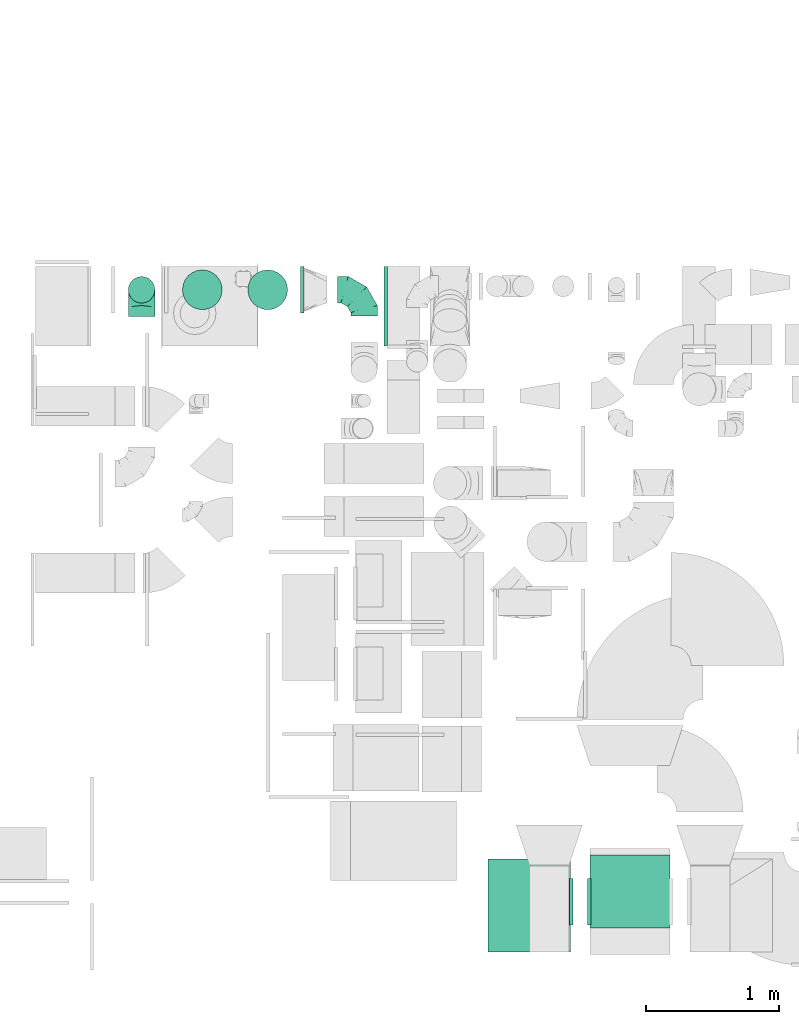
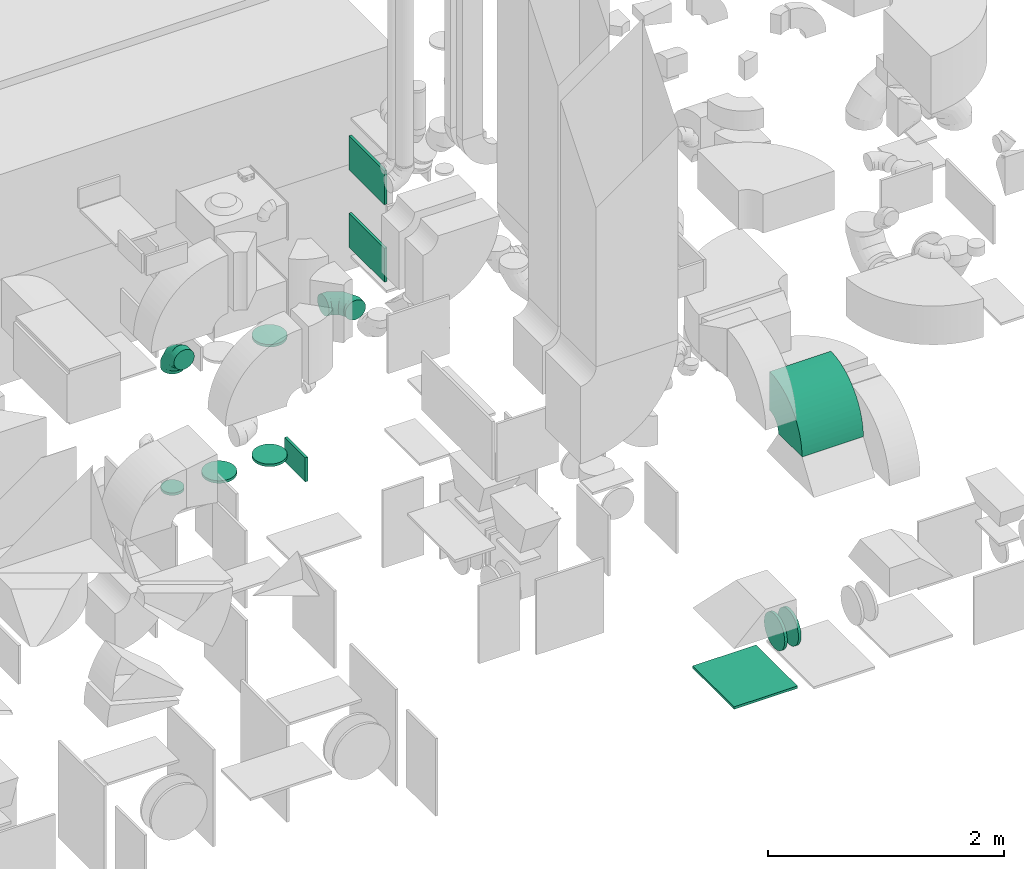
# One storey, part 19 of 59: 13 flow fittings.
"""IFC2X3 building model written with IfcOpenShell, lengths in millimetres."""

from ifc_helpers import new_model, entity, si_unit, converted_unit, derived_unit, direction, frame, frame_2d, origin, origin_2d_with_axis, place, context, subcontext, project, spatial, polyline, circle_curve, parameter, trimmed, segment, composite_curve, rectangle, outline, extrude, faceted_brep, source, transform, mapped, material, type_object, type_shapes, element, save


model = new_model("IFC2X3")

# Units and contexts
model_context = context("Model", 3, precision=0.01, world=origin(), true_north=direction((6.12303176911189e-17, 1.0)))
body_context = subcontext(model_context, "Body", "Model", "MODEL_VIEW")
ifc_project = project(units=[si_unit("LENGTHUNIT", "METRE", prefix="MILLI"), si_unit("AREAUNIT", "SQUARE_METRE"), si_unit("VOLUMEUNIT", "CUBIC_METRE"), converted_unit("PLANEANGLEUNIT", "DEGREE", entity("IfcRatioMeasure", 0.0174532925199433), si_unit("PLANEANGLEUNIT", "RADIAN"), dimensions=[0, 0, 0, 0, 0, 0, 0]), si_unit("MASSUNIT", "GRAM", prefix="KILO"), derived_unit("MASSDENSITYUNIT", [(si_unit("MASSUNIT", "GRAM", prefix="KILO"), 1), (si_unit("LENGTHUNIT", "METRE"), -3)]), derived_unit("MOMENTOFINERTIAUNIT", [(si_unit("LENGTHUNIT", "METRE"), 4)]), si_unit("TIMEUNIT", "SECOND"), si_unit("FREQUENCYUNIT", "HERTZ"), si_unit("THERMODYNAMICTEMPERATUREUNIT", "DEGREE_CELSIUS"), derived_unit("THERMALTRANSMITTANCEUNIT", [(si_unit("MASSUNIT", "GRAM", prefix="KILO"), 1), (si_unit("THERMODYNAMICTEMPERATUREUNIT", "KELVIN"), -1), (si_unit("TIMEUNIT", "SECOND"), -3)]), derived_unit("VOLUMETRICFLOWRATEUNIT", [(si_unit("LENGTHUNIT", "METRE"), 3), (si_unit("TIMEUNIT", "SECOND"), -1)]), derived_unit("MASSFLOWRATEUNIT", [(si_unit("MASSUNIT", "GRAM", prefix="KILO"), 1), (si_unit("TIMEUNIT", "SECOND"), -1)]), derived_unit("ROTATIONALFREQUENCYUNIT", [(si_unit("TIMEUNIT", "SECOND"), -1)]), si_unit("ELECTRICCURRENTUNIT", "AMPERE"), si_unit("ELECTRICVOLTAGEUNIT", "VOLT"), si_unit("POWERUNIT", "WATT"), si_unit("FORCEUNIT", "NEWTON", prefix="KILO"), si_unit("ILLUMINANCEUNIT", "LUX"), si_unit("LUMINOUSFLUXUNIT", "LUMEN"), si_unit("LUMINOUSINTENSITYUNIT", "CANDELA"), derived_unit("USERDEFINED", [(si_unit("MASSUNIT", "GRAM", prefix="KILO"), -1), (si_unit("LENGTHUNIT", "METRE"), -2), (si_unit("TIMEUNIT", "SECOND"), 3), (si_unit("LUMINOUSFLUXUNIT", "LUMEN"), 1)]), derived_unit("LINEARVELOCITYUNIT", [(si_unit("LENGTHUNIT", "METRE"), 1), (si_unit("TIMEUNIT", "SECOND"), -1)]), si_unit("PRESSUREUNIT", "PASCAL"), derived_unit("USERDEFINED", [(si_unit("LENGTHUNIT", "METRE"), -2), (si_unit("MASSUNIT", "GRAM", prefix="KILO"), 1), (si_unit("TIMEUNIT", "SECOND"), -2)]), derived_unit("LINEARFORCEUNIT", [(si_unit("MASSUNIT", "GRAM", prefix="KILO"), 1), (si_unit("LENGTHUNIT", "METRE"), 1), (si_unit("TIMEUNIT", "SECOND"), -2), (si_unit("LENGTHUNIT", "METRE"), -1)]), derived_unit("PLANARFORCEUNIT", [(si_unit("MASSUNIT", "GRAM", prefix="KILO"), 1), (si_unit("LENGTHUNIT", "METRE"), 1), (si_unit("TIMEUNIT", "SECOND"), -2), (si_unit("LENGTHUNIT", "METRE"), -2)])], contexts=[model_context])

# Site, building, storey
site_placement = place(None, origin())
site = spatial("IfcSite", under=ifc_project, at=site_placement, CompositionType="ELEMENT")
building_placement = place(site_placement, origin())
building = spatial("IfcBuilding", under=site, at=building_placement, CompositionType="ELEMENT")
storey_placement = place(building_placement, frame((0.0, 0.0, 28200.0)))
storey = spatial("IfcBuildingStorey", under=building, at=storey_placement, CompositionType="ELEMENT", Elevation=28200.0)

# Flow fittings
ifc_material = material()
duct_fitting_type_1 = type_object("IfcDuctFittingType", PredefinedType="NOTDEFINED", material=ifc_material)
shared_shape_1 = source(origin(), body_context, "Body", "SweptSolid", [
    extrude(rectangle(XDim=24.9999999999999, YDim=350.0, at=origin_2d_with_axis()), frame((12.5, 0.0, -125.0)), (0.0, 0.0, 1.0), 250.0),
])
type_shapes(duct_fitting_type_1, [shared_shape_1])
flow_fitting_1_placement = place(storey_placement, frame((47891.97, 12998.12, 325.0)))
element("IfcFlowFitting", 1, at=flow_fitting_1_placement, inside=storey, type_object=duct_fitting_type_1, material=ifc_material, context=body_context, shape_type="MappedRepresentation", body=[
    mapped(shared_shape_1, transform((0.0, 0.0, 0.0), scale=1.0)),
])
duct_fitting_type_2 = type_object("IfcDuctFittingType", PredefinedType="NOTDEFINED", material=ifc_material)
shared_shape_2 = source(origin(), body_context, "Body", "SweptSolid", [
    extrude(rectangle(XDim=350.0, YDim=26.096, at=origin_2d_with_axis()), frame((6.95, 0.0, -300.0), z_axis=(0.0, 0.0, 1.0), x_axis=(0.0, -1.0, 0.0)), (0.0, 0.0, 1.0), 600.0),
])
type_shapes(duct_fitting_type_2, [shared_shape_2])
for number, where, z_axis, x_axis in (
    (2, (48542.04, 12874.75, 2370.0), (0.0, 1.0, 0.0), (-1.0, 0.0, 0.0)),
    (3, (48542.04, 12874.75, 3170.0), (0.0, 1.0, 0.0), (-1.0, 0.0, 0.0)),
):
    element("IfcFlowFitting", number, at=place(storey_placement, frame(where, z_axis=z_axis, x_axis=x_axis)), inside=storey, type_object=duct_fitting_type_2, material=ifc_material, context=body_context, shape_type="MappedRepresentation", body=[
        mapped(shared_shape_2, transform((0.0, 0.0, 0.0), scale=1.0)),
    ])
duct_fitting_type_3 = type_object("IfcDuctFittingType", PredefinedType="NOTDEFINED", material=ifc_material)
shared_shape_3 = source(origin(), body_context, "Body", "SweptSolid", [
    extrude(rectangle(XDim=24.9999999999999, YDim=620.0, at=origin_2d_with_axis()), frame((12.5, 0.0, -350.0)), (0.0, 0.0, 1.0), 700.0),
])
type_shapes(duct_fitting_type_3, [shared_shape_3])
flow_fitting_2_placement = place(storey_placement, frame((49615.11, 8360.0, 300.0), z_axis=(0.0, 1.0, 0.0), x_axis=(0.0, 0.0, -1.0)))
element("IfcFlowFitting", 4, at=flow_fitting_2_placement, inside=storey, type_object=duct_fitting_type_3, material=ifc_material, context=body_context, shape_type="MappedRepresentation", body=[
    mapped(shared_shape_3, transform((0.0, 0.0, 0.0), scale=1.0)),
])
duct_fitting_type_4 = type_object("IfcDuctFittingType", PredefinedType="NOTDEFINED", material=ifc_material)
shared_shape_4 = source(origin(), body_context, "Body", "Brep", [
    faceted_brep([(-200.0, 0.0, -100.0), (-200.0, -25.88, -96.59), (-200.0, -50.0, -86.6), (-200.0, -70.71, -70.71), (-200.0, -86.6, -50.0), (-200.0, -96.59, -25.88), (-200.0, -100.0, 0.0), (-200.0, -96.59, 25.88), (-200.0, -86.6, 50.0), (-200.0, -70.71, 70.71), (-200.0, -50.0, 86.6), (-200.0, -25.88, 96.59), (-200.0, 0.0, 100.0), (-200.0, 25.88, 96.59), (-200.0, 50.0, 86.6), (-200.0, 70.71, 70.71), (-200.0, 86.6, 50.0), (-200.0, 96.59, 25.88), (-200.0, 100.0, 0.0), (-200.0, 96.59, -25.88), (-200.0, 86.6, -50.0), (-200.0, 70.71, -70.71), (-200.0, 50.0, -86.6), (-200.0, 25.88, -96.59), (-153.35, 25.88, 96.59), (-159.81, 50.0, 86.6), (-146.41, 0.0, 100.0), (-165.36, 70.71, 70.71), (-172.29, 96.59, 25.88), (-173.21, 100.0, 0.0), (-169.62, 86.6, 50.0), (-169.62, 86.6, -50.0), (-165.36, 70.71, -70.71), (-172.29, 96.59, -25.88), (-153.35, 25.88, -96.59), (-146.41, 0.0, -100.0), (-159.81, 50.0, -86.6), (-139.48, -25.88, -96.59), (-133.01, -50.0, -86.6), (-127.46, -70.71, -70.71), (-123.21, -86.6, -50.0), (-120.53, -96.59, -25.88), (-119.62, -100.0, 0.0), (-120.53, -96.59, 25.88), (-123.21, -86.6, 50.0), (-127.46, -70.71, 70.71), (-133.01, -50.0, 86.6), (-139.48, -25.88, 96.59), (-72.54, 72.54, 96.59), (-90.19, 90.19, 86.6), (-53.59, 53.59, 100.0), (-105.35, 105.35, 70.71), (-116.99, 116.99, 50.0), (-124.3, 124.3, 25.88), (-126.79, 126.79, 0.0), (-124.3, 124.3, -25.88), (-116.99, 116.99, -50.0), (-105.35, 105.35, -70.71), (-72.54, 72.54, -96.59), (-53.59, 53.59, -100.0), (-90.19, 90.19, -86.6), (-34.64, 34.64, -96.59), (-16.99, 16.99, -86.6), (-1.83, 1.83, -70.71), (9.81, -9.81, -50.0), (17.12, -17.12, -25.88), (19.62, -19.62, 0.0), (17.12, -17.12, 25.88), (9.81, -9.81, 50.0), (-1.83, 1.83, 70.71), (-16.99, 16.99, 86.6), (-34.64, 34.64, 96.59), (-25.88, 153.35, 96.59), (-50.0, 159.81, 86.6), (0.0, 146.41, 100.0), (-70.71, 165.36, 70.71), (-86.6, 169.62, 50.0), (-96.59, 172.29, 25.88), (-100.0, 173.21, 0.0), (-96.59, 172.29, -25.88), (-86.6, 169.62, -50.0), (-70.71, 165.36, -70.71), (-25.88, 153.35, -96.59), (0.0, 146.41, -100.0), (-50.0, 159.81, -86.6), (25.88, 139.48, -96.59), (50.0, 133.01, -86.6), (70.71, 127.46, -70.71), (86.6, 123.21, -50.0), (96.59, 120.53, -25.88), (100.0, 119.62, 0.0), (96.59, 120.53, 25.88), (86.6, 123.21, 50.0), (70.71, 127.46, 70.71), (50.0, 133.01, 86.6), (25.88, 139.48, 96.59), (-25.88, 200.0, -96.59), (-50.0, 200.0, -86.6), (-70.71, 200.0, -70.71), (-86.6, 200.0, -50.0), (-96.59, 200.0, -25.88), (-100.0, 200.0, 0.0), (-96.59, 200.0, 25.88), (-86.6, 200.0, 50.0), (-70.71, 200.0, 70.71), (-50.0, 200.0, 86.6), (-25.88, 200.0, 96.59), (0.0, 200.0, 100.0), (25.88, 200.0, 96.59), (50.0, 200.0, 86.6), (70.71, 200.0, 70.71), (86.6, 200.0, 50.0), (96.59, 200.0, 25.88), (100.0, 200.0, 0.0), (96.59, 200.0, -25.88), (86.6, 200.0, -50.0), (70.71, 200.0, -70.71), (50.0, 200.0, -86.6), (25.88, 200.0, -96.59), (0.0, 200.0, -100.0)], [[[0, 1, 2, 3, 4, 5, 6, 7, 8, 9, 10, 11, 12, 13, 14, 15, 16, 17, 18, 19, 20, 21, 22, 23]], [[24, 25, 14, 13]], [[26, 24, 13, 12]], [[14, 25, 27, 15]], [[28, 29, 18, 17]], [[30, 28, 17, 16]], [[15, 27, 30, 16]], [[20, 31, 32, 21]], [[33, 31, 20, 19]], [[18, 29, 33, 19]], [[34, 35, 0, 23]], [[36, 34, 23, 22]], [[32, 36, 22, 21]], [[1, 0, 35, 37]], [[2, 1, 37, 38]], [[38, 39, 3, 2]], [[5, 4, 40, 41]], [[6, 5, 41, 42]], [[39, 40, 4, 3]], [[6, 42, 43, 7]], [[7, 43, 44, 8]], [[8, 44, 45, 9]], [[9, 45, 46, 10]], [[10, 46, 47, 11]], [[26, 12, 11, 47]], [[48, 49, 25, 24]], [[50, 48, 24, 26]], [[27, 25, 49, 51]], [[52, 53, 28, 30]], [[51, 52, 30, 27]], [[29, 28, 53, 54]], [[55, 56, 31, 33]], [[54, 55, 33, 29]], [[32, 31, 56, 57]], [[58, 59, 35, 34]], [[60, 58, 34, 36]], [[57, 60, 36, 32]], [[37, 35, 59, 61]], [[38, 37, 61, 62]], [[39, 38, 62, 63]], [[41, 40, 64, 65]], [[42, 41, 65, 66]], [[63, 64, 40, 39]], [[43, 42, 66, 67]], [[44, 43, 67, 68]], [[68, 69, 45, 44]], [[46, 45, 69, 70]], [[47, 46, 70, 71]], [[26, 47, 71, 50]], [[72, 73, 49, 48]], [[74, 72, 48, 50]], [[51, 49, 73, 75]], [[76, 77, 53, 52]], [[75, 76, 52, 51]], [[54, 53, 77, 78]], [[79, 80, 56, 55]], [[78, 79, 55, 54]], [[57, 56, 80, 81]], [[82, 83, 59, 58]], [[84, 82, 58, 60]], [[81, 84, 60, 57]], [[61, 59, 83, 85]], [[62, 61, 85, 86]], [[63, 62, 86, 87]], [[65, 64, 88, 89]], [[66, 65, 89, 90]], [[87, 88, 64, 63]], [[67, 66, 90, 91]], [[68, 67, 91, 92]], [[92, 93, 69, 68]], [[70, 69, 93, 94]], [[71, 70, 94, 95]], [[50, 71, 95, 74]], [[96, 97, 98, 99, 100, 101, 102, 103, 104, 105, 106, 107, 108, 109, 110, 111, 112, 113, 114, 115, 116, 117, 118, 119]], [[72, 74, 107, 106]], [[73, 72, 106, 105]], [[75, 73, 105, 104]], [[102, 101, 78, 77]], [[103, 102, 77, 76]], [[75, 104, 103, 76]], [[78, 101, 100, 79]], [[79, 100, 99, 80]], [[80, 99, 98, 81]], [[84, 97, 96, 82]], [[82, 96, 119, 83]], [[84, 81, 98, 97]], [[118, 117, 86, 85]], [[119, 118, 85, 83]], [[116, 87, 86, 117]], [[88, 115, 114, 89]], [[89, 114, 113, 90]], [[115, 88, 87, 116]], [[91, 90, 113, 112]], [[92, 91, 112, 111]], [[111, 110, 93, 92]], [[95, 94, 109, 108]], [[74, 95, 108, 107]], [[110, 109, 94, 93]]]),
])
type_shapes(duct_fitting_type_4, [shared_shape_4])
for number, where, z_axis, x_axis in (
    (5, (48370.11, 12999.59, 1825.0), (0.0, 0.0, 1.0), (0.0, 1.0, 0.0)),
    (6, (46694.47, 12998.12, 1900.0), (1.0, 0.0, 0.0), (0.0, 0.0, 1.0)),
):
    element("IfcFlowFitting", number, at=place(storey_placement, frame(where, z_axis=z_axis, x_axis=x_axis)), inside=storey, type_object=duct_fitting_type_4, material=ifc_material, context=body_context, shape_type="MappedRepresentation", body=[
        mapped(shared_shape_4, transform((0.0, 0.0, 0.0), scale=1.0)),
    ])
duct_fitting_type_5 = type_object("IfcDuctFittingType", PredefinedType="NOTDEFINED", material=ifc_material)
shared_shape_5 = source(origin(), body_context, "Body", "Brep", [
    faceted_brep([(20.0, 0.0, -100.0), (20.0, 25.88, -96.59), (20.0, 50.0, -86.6), (20.0, 70.71, -70.71), (20.0, 86.6, -50.0), (20.0, 96.59, -25.88), (20.0, 100.0, 0.0), (20.0, 96.59, 25.88), (20.0, 86.6, 50.0), (20.0, 70.71, 70.71), (20.0, 50.0, 86.6), (20.0, 25.88, 96.59), (20.0, 0.0, 100.0), (20.0, -25.88, 96.59), (20.0, -50.0, 86.6), (20.0, -70.71, 70.71), (20.0, -86.6, 50.0), (20.0, -96.59, 25.88), (20.0, -100.0, 0.0), (20.0, -96.59, -25.88), (20.0, -86.6, -50.0), (20.0, -70.71, -70.71), (20.0, -50.0, -86.6), (20.0, -25.88, -96.59), (0.0, 0.0, 100.0), (-6.1, 0.0, 100.0), (-6.1, -25.88, 96.59), (0.0, -25.88, 96.59), (-6.1, -50.0, 86.6), (0.0, -50.0, 86.6), (0.0, -70.71, 70.71), (-6.1, -70.71, 70.71), (0.0, -86.6, 50.0), (-6.1, -86.6, 50.0), (-6.1, -96.59, 25.88), (0.0, -96.59, 25.88), (-6.1, -100.0, 0.0), (0.0, -100.0, 0.0), (-6.1, -96.59, -25.88), (0.0, -96.59, -25.88), (-6.1, -86.6, -50.0), (0.0, -86.6, -50.0), (0.0, -70.71, -70.71), (-6.1, -70.71, -70.71), (0.0, -50.0, -86.6), (-6.1, -50.0, -86.6), (-6.1, -25.88, -96.59), (0.0, -25.88, -96.59), (-6.1, 0.0, -100.0), (0.0, 0.0, -100.0), (-6.1, 25.88, -96.59), (0.0, 25.88, -96.59), (-6.1, 50.0, -86.6), (0.0, 50.0, -86.6), (0.0, 70.71, -70.71), (-6.1, 70.71, -70.71), (0.0, 86.6, -50.0), (-6.1, 86.6, -50.0), (-6.1, 96.59, -25.88), (0.0, 96.59, -25.88), (-6.1, 100.0, 0.0), (0.0, 100.0, 0.0), (-6.1, 96.59, 25.88), (0.0, 96.59, 25.88), (-6.1, 86.6, 50.0), (0.0, 86.6, 50.0), (0.0, 70.71, 70.71), (-6.1, 70.71, 70.71), (0.0, 50.0, 86.6), (-6.1, 50.0, 86.6), (-6.1, 25.88, 96.59), (0.0, 25.88, 96.59)], [[[0, 1, 2, 3, 4, 5, 6, 7, 8, 9, 10, 11, 12, 13, 14, 15, 16, 17, 18, 19, 20, 21, 22, 23]], [[13, 12, 24, 25, 26, 27]], [[14, 13, 27, 26, 28, 29]], [[30, 15, 14, 29, 28, 31]], [[17, 16, 32, 33, 34, 35]], [[18, 17, 35, 34, 36, 37]], [[32, 16, 15, 30, 31, 33]], [[19, 18, 37, 36, 38, 39]], [[20, 19, 39, 38, 40, 41]], [[42, 21, 20, 41, 40, 43]], [[23, 22, 44, 45, 46, 47]], [[0, 23, 47, 46, 48, 49]], [[44, 22, 21, 42, 43, 45]], [[1, 0, 49, 48, 50, 51]], [[2, 1, 51, 50, 52, 53]], [[54, 3, 2, 53, 52, 55]], [[5, 4, 56, 57, 58, 59]], [[6, 5, 59, 58, 60, 61]], [[56, 4, 3, 54, 55, 57]], [[7, 6, 61, 60, 62, 63]], [[8, 7, 63, 62, 64, 65]], [[66, 9, 8, 65, 64, 67]], [[11, 10, 68, 69, 70, 71]], [[12, 11, 71, 70, 25, 24]], [[68, 10, 9, 66, 67, 69]], [[46, 45, 43, 40, 38, 36, 34, 33, 31, 28, 26, 25, 70, 69, 67, 64, 62, 60, 58, 57, 55, 52, 50, 48]]]),
])
type_shapes(duct_fitting_type_5, [shared_shape_5])
flow_fitting_3_placement = place(storey_placement, frame((46694.47, 12998.12, 450.0), z_axis=(1.0, 0.0, 0.0), x_axis=(0.0, 0.0, 1.0)))
element("IfcFlowFitting", 7, at=flow_fitting_3_placement, inside=storey, type_object=duct_fitting_type_5, material=ifc_material, context=body_context, shape_type="MappedRepresentation", body=[
    mapped(shared_shape_5, transform((0.0, 0.0, 0.0), scale=1.0)),
])
duct_fitting_type_6 = type_object("IfcDuctFittingType", PredefinedType="NOTDEFINED", material=ifc_material)
shared_shape_6 = source(origin(), body_context, "Body", "Brep", [
    faceted_brep([(20.0, 0.0, -150.0), (20.0, 38.82, -144.89), (20.0, 75.0, -129.9), (20.0, 106.07, -106.07), (20.0, 129.9, -75.0), (20.0, 144.89, -38.82), (20.0, 150.0, 0.0), (20.0, 144.89, 38.82), (20.0, 129.9, 75.0), (20.0, 106.07, 106.07), (20.0, 75.0, 129.9), (20.0, 38.82, 144.89), (20.0, 0.0, 150.0), (20.0, -38.82, 144.89), (20.0, -75.0, 129.9), (20.0, -106.07, 106.07), (20.0, -129.9, 75.0), (20.0, -144.89, 38.82), (20.0, -150.0, 0.0), (20.0, -144.89, -38.82), (20.0, -129.9, -75.0), (20.0, -106.07, -106.07), (20.0, -75.0, -129.9), (20.0, -38.82, -144.89), (0.0, 0.0, 150.0), (-6.1, 0.0, 150.0), (-6.1, -38.82, 144.89), (0.0, -38.82, 144.89), (-6.1, -75.0, 129.9), (0.0, -75.0, 129.9), (0.0, -106.07, 106.07), (-6.1, -106.07, 106.07), (0.0, -129.9, 75.0), (-6.1, -129.9, 75.0), (-6.1, -144.89, 38.82), (0.0, -144.89, 38.82), (-6.1, -150.0, 0.0), (0.0, -150.0, 0.0), (-6.1, -144.89, -38.82), (0.0, -144.89, -38.82), (-6.1, -129.9, -75.0), (0.0, -129.9, -75.0), (0.0, -106.07, -106.07), (-6.1, -106.07, -106.07), (0.0, -75.0, -129.9), (-6.1, -75.0, -129.9), (-6.1, -38.82, -144.89), (0.0, -38.82, -144.89), (-6.1, 0.0, -150.0), (0.0, 0.0, -150.0), (-6.1, 38.82, -144.89), (0.0, 38.82, -144.89), (-6.1, 75.0, -129.9), (0.0, 75.0, -129.9), (0.0, 106.07, -106.07), (-6.1, 106.07, -106.07), (0.0, 129.9, -75.0), (-6.1, 129.9, -75.0), (-6.1, 144.89, -38.82), (0.0, 144.89, -38.82), (-6.1, 150.0, 0.0), (0.0, 150.0, 0.0), (-6.1, 144.89, 38.82), (0.0, 144.89, 38.82), (-6.1, 129.9, 75.0), (0.0, 129.9, 75.0), (0.0, 106.07, 106.07), (-6.1, 106.07, 106.07), (0.0, 75.0, 129.9), (-6.1, 75.0, 129.9), (-6.1, 38.82, 144.89), (0.0, 38.82, 144.89)], [[[0, 1, 2, 3, 4, 5, 6, 7, 8, 9, 10, 11, 12, 13, 14, 15, 16, 17, 18, 19, 20, 21, 22, 23]], [[13, 12, 24, 25, 26, 27]], [[14, 13, 27, 26, 28, 29]], [[30, 15, 14, 29, 28, 31]], [[17, 16, 32, 33, 34, 35]], [[18, 17, 35, 34, 36, 37]], [[32, 16, 15, 30, 31, 33]], [[19, 18, 37, 36, 38, 39]], [[20, 19, 39, 38, 40, 41]], [[42, 21, 20, 41, 40, 43]], [[23, 22, 44, 45, 46, 47]], [[0, 23, 47, 46, 48, 49]], [[44, 22, 21, 42, 43, 45]], [[1, 0, 49, 48, 50, 51]], [[2, 1, 51, 50, 52, 53]], [[54, 3, 2, 53, 52, 55]], [[5, 4, 56, 57, 58, 59]], [[6, 5, 59, 58, 60, 61]], [[56, 4, 3, 54, 55, 57]], [[7, 6, 61, 60, 62, 63]], [[8, 7, 63, 62, 64, 65]], [[66, 9, 8, 65, 64, 67]], [[11, 10, 68, 69, 70, 71]], [[12, 11, 71, 70, 25, 24]], [[68, 10, 9, 66, 67, 69]], [[46, 45, 43, 40, 38, 36, 34, 33, 31, 28, 26, 25, 70, 69, 67, 64, 62, 60, 58, 57, 55, 52, 50, 48]]]),
])
type_shapes(duct_fitting_type_6, [shared_shape_6])
flow_fitting_4_placement = place(storey_placement, frame((47644.47, 12998.12, 1700.0), z_axis=(1.0, 0.0, 0.0), x_axis=(0.0, 0.0, -1.0)))
element("IfcFlowFitting", 8, at=flow_fitting_4_placement, inside=storey, type_object=duct_fitting_type_6, material=ifc_material, context=body_context, shape_type="MappedRepresentation", body=[
    mapped(shared_shape_6, transform((0.0, 0.0, 0.0), scale=1.0)),
])
duct_fitting_type_7 = type_object("IfcDuctFittingType", PredefinedType="NOTDEFINED", material=ifc_material)
shared_shape_7 = source(origin(), body_context, "Body", "Brep", [
    faceted_brep([(20.0, 38.82, -144.89), (20.0, 75.0, -129.9), (20.0, 106.07, -106.07), (20.0, 129.9, -75.0), (20.0, 144.89, -38.82), (20.0, 150.0, 0.0), (20.0, 144.89, 38.82), (20.0, 129.9, 75.0), (20.0, 106.07, 106.07), (20.0, 75.0, 129.9), (20.0, 38.82, 144.89), (20.0, 0.0, 150.0), (20.0, -38.82, 144.89), (20.0, -75.0, 129.9), (20.0, -106.07, 106.07), (20.0, -129.9, 75.0), (20.0, -144.89, 38.82), (20.0, -150.0, 0.0), (20.0, -144.89, -38.82), (20.0, -129.9, -75.0), (20.0, -106.07, -106.07), (20.0, -75.0, -129.9), (20.0, -38.82, -144.89), (20.0, 0.0, -150.0), (0.0, 0.0, 150.0), (0.0, 38.82, 144.89), (-6.1, 38.82, 144.89), (-6.1, 0.0, 150.0), (0.0, 75.0, 129.9), (-6.1, 75.0, 129.9), (0.0, 106.07, 106.07), (-6.1, 106.07, 106.07), (0.0, 129.9, 75.0), (0.0, 144.89, 38.82), (-6.1, 144.89, 38.82), (-6.1, 129.9, 75.0), (0.0, 150.0, 0.0), (-6.1, 150.0, 0.0), (0.0, 144.89, -38.82), (-6.1, 144.89, -38.82), (0.0, 129.9, -75.0), (-6.1, 129.9, -75.0), (0.0, 106.07, -106.07), (-6.1, 106.07, -106.07), (0.0, 75.0, -129.9), (0.0, 38.82, -144.89), (-6.1, 38.82, -144.89), (-6.1, 75.0, -129.9), (0.0, 0.0, -150.0), (-6.1, 0.0, -150.0), (0.0, -38.82, -144.89), (-6.1, -38.82, -144.89), (0.0, -75.0, -129.9), (-6.1, -75.0, -129.9), (0.0, -106.07, -106.07), (-6.1, -106.07, -106.07), (0.0, -129.9, -75.0), (0.0, -144.89, -38.82), (-6.1, -144.89, -38.82), (-6.1, -129.9, -75.0), (0.0, -150.0, 0.0), (-6.1, -150.0, 0.0), (0.0, -144.89, 38.82), (-6.1, -144.89, 38.82), (0.0, -129.9, 75.0), (-6.1, -129.9, 75.0), (0.0, -106.07, 106.07), (-6.1, -106.07, 106.07), (0.0, -75.0, 129.9), (0.0, -38.82, 144.89), (-6.1, -38.82, 144.89), (-6.1, -75.0, 129.9)], [[[0, 1, 2, 3, 4, 5, 6, 7, 8, 9, 10, 11, 12, 13, 14, 15, 16, 17, 18, 19, 20, 21, 22, 23]], [[24, 11, 10, 25, 26, 27]], [[25, 10, 9, 28, 29, 26]], [[28, 9, 8, 30, 31, 29]], [[32, 7, 6, 33, 34, 35]], [[33, 6, 5, 36, 37, 34]], [[30, 8, 7, 32, 35, 31]], [[36, 5, 4, 38, 39, 37]], [[38, 4, 3, 40, 41, 39]], [[40, 3, 2, 42, 43, 41]], [[44, 1, 0, 45, 46, 47]], [[45, 0, 23, 48, 49, 46]], [[42, 2, 1, 44, 47, 43]], [[48, 23, 22, 50, 51, 49]], [[50, 22, 21, 52, 53, 51]], [[52, 21, 20, 54, 55, 53]], [[56, 19, 18, 57, 58, 59]], [[57, 18, 17, 60, 61, 58]], [[54, 20, 19, 56, 59, 55]], [[60, 17, 16, 62, 63, 61]], [[62, 16, 15, 64, 65, 63]], [[64, 15, 14, 66, 67, 65]], [[68, 13, 12, 69, 70, 71]], [[69, 12, 11, 24, 27, 70]], [[66, 14, 13, 68, 71, 67]], [[49, 51, 53, 55, 59, 58, 61, 63, 65, 67, 71, 70, 27, 26, 29, 31, 35, 34, 37, 39, 41, 43, 47, 46]]]),
])
type_shapes(duct_fitting_type_7, [shared_shape_7])
for number, where, z_axis, x_axis in (
    (9, (47151.97, 12998.12, 450.0), (-1.0, 0.0, 0.0), (0.0, 0.0, 1.0)),
    (10, (47644.47, 12998.12, 450.0), (-1.0, 0.0, 0.0), (0.0, 0.0, 1.0)),
):
    element("IfcFlowFitting", number, at=place(storey_placement, frame(where, z_axis=z_axis, x_axis=x_axis)), inside=storey, type_object=duct_fitting_type_7, material=ifc_material, context=body_context, shape_type="MappedRepresentation", body=[
        mapped(shared_shape_7, transform((0.0, 0.0, 0.0), scale=1.0)),
    ])
duct_fitting_type_8 = type_object("IfcDuctFittingType", PredefinedType="NOTDEFINED", material=ifc_material)
shared_shape_8 = source(origin(), body_context, "Body", "Brep", [
    faceted_brep([(20.0, 0.0, -175.0), (20.0, 45.29, -169.04), (20.0, 87.5, -151.55), (20.0, 123.74, -123.74), (20.0, 151.55, -87.5), (20.0, 169.04, -45.29), (20.0, 175.0, 0.0), (20.0, 169.04, 45.29), (20.0, 151.55, 87.5), (20.0, 123.74, 123.74), (20.0, 87.5, 151.55), (20.0, 45.29, 169.04), (20.0, 0.0, 175.0), (20.0, -45.29, 169.04), (20.0, -87.5, 151.55), (20.0, -123.74, 123.74), (20.0, -151.55, 87.5), (20.0, -169.04, 45.29), (20.0, -175.0, 0.0), (20.0, -169.04, -45.29), (20.0, -151.55, -87.5), (20.0, -123.74, -123.74), (20.0, -87.5, -151.55), (20.0, -45.29, -169.04), (0.0, 0.0, 175.0), (0.0, -28.54, 171.24), (0.0, -45.29, 169.04), (-6.1, -22.65, 172.02), (-6.1, 0.0, 175.0), (-6.1, -45.29, 169.04), (0.0, -66.4, 160.3), (0.0, -87.5, 151.55), (-6.1, -66.4, 160.3), (-6.1, -87.5, 151.55), (0.0, -105.62, 137.65), (0.0, -123.74, 123.74), (-6.1, -105.62, 137.65), (-6.1, -123.74, 123.74), (0.0, -151.55, 87.5), (0.0, -160.3, 66.4), (0.0, -169.04, 45.29), (-6.1, -151.55, 87.5), (-6.1, -160.3, 66.4), (-6.1, -169.04, 45.29), (0.0, -172.02, 22.65), (0.0, -175.0, 0.0), (-6.1, -171.24, 28.54), (-6.1, -175.0, 0.0), (0.0, -137.65, 105.62), (-6.1, -137.65, 105.62), (0.0, -171.24, -28.54), (0.0, -169.04, -45.29), (-6.1, -172.02, -22.65), (-6.1, -169.04, -45.29), (0.0, -160.3, -66.4), (0.0, -151.55, -87.5), (-6.1, -160.3, -66.4), (-6.1, -151.55, -87.5), (0.0, -137.65, -105.62), (0.0, -123.74, -123.74), (-6.1, -137.65, -105.62), (-6.1, -123.74, -123.74), (0.0, -87.5, -151.55), (0.0, -66.4, -160.3), (0.0, -45.29, -169.04), (-6.1, -66.4, -160.3), (-6.1, -87.5, -151.55), (-6.1, -45.29, -169.04), (0.0, 0.0, -175.0), (0.0, -28.54, -171.24), (-6.1, -22.65, -172.02), (-6.1, 0.0, -175.0), (0.0, -105.62, -137.65), (-6.1, -105.62, -137.65), (0.0, 28.54, -171.24), (0.0, 45.29, -169.04), (-6.1, 22.65, -172.02), (-6.1, 45.29, -169.04), (0.0, 66.4, -160.3), (0.0, 87.5, -151.55), (-6.1, 66.4, -160.3), (-6.1, 87.5, -151.55), (0.0, 105.62, -137.65), (0.0, 123.74, -123.74), (-6.1, 105.62, -137.65), (-6.1, 123.74, -123.74), (0.0, 175.0, 0.0), (0.0, 171.24, -28.54), (-6.1, 172.02, -22.65), (-6.1, 175.0, 0.0), (0.0, 169.04, -45.29), (-6.1, 169.04, -45.29), (0.0, 151.55, -87.5), (0.0, 160.3, -66.4), (-6.1, 151.55, -87.5), (-6.1, 160.3, -66.4), (0.0, 137.65, -105.62), (-6.1, 137.65, -105.62), (0.0, 171.24, 28.54), (0.0, 169.04, 45.29), (-6.1, 172.02, 22.65), (-6.1, 169.04, 45.29), (0.0, 160.3, 66.4), (0.0, 151.55, 87.5), (-6.1, 160.3, 66.4), (-6.1, 151.55, 87.5), (0.0, 137.65, 105.62), (0.0, 123.74, 123.74), (-6.1, 137.65, 105.62), (-6.1, 123.74, 123.74), (0.0, 87.5, 151.55), (0.0, 66.4, 160.3), (0.0, 45.29, 169.04), (-6.1, 87.5, 151.55), (-6.1, 66.4, 160.3), (-6.1, 45.29, 169.04), (0.0, 22.65, 172.02), (-6.1, 28.54, 171.24), (0.0, 105.62, 137.65), (-6.1, 105.62, 137.65)], [[[0, 1, 2, 3, 4, 5, 6, 7, 8, 9, 10, 11, 12, 13, 14, 15, 16, 17, 18, 19, 20, 21, 22, 23]], [[13, 12, 24]], [[13, 24, 25]], [[13, 25, 26]], [[27, 25, 24]], [[27, 24, 28]], [[27, 29, 25]], [[25, 29, 26]], [[14, 13, 26]], [[14, 26, 30]], [[14, 30, 31]], [[26, 29, 30]], [[32, 30, 29]], [[30, 32, 31]], [[32, 33, 31]], [[15, 31, 34]], [[14, 31, 15]], [[15, 34, 35]], [[34, 31, 33]], [[34, 33, 36]], [[36, 37, 35]], [[34, 36, 35]], [[17, 16, 38]], [[17, 38, 39]], [[17, 39, 40]], [[38, 41, 39]], [[42, 39, 41]], [[39, 42, 40]], [[42, 43, 40]], [[18, 17, 40]], [[18, 40, 44]], [[18, 44, 45]], [[44, 40, 46]], [[43, 46, 40]], [[44, 46, 47]], [[45, 44, 47]], [[16, 35, 48]], [[15, 35, 16]], [[16, 48, 38]], [[48, 35, 37]], [[48, 37, 49]], [[48, 49, 38]], [[49, 41, 38]], [[19, 18, 45]], [[19, 45, 50]], [[19, 50, 51]], [[52, 50, 45]], [[52, 45, 47]], [[52, 53, 50]], [[50, 53, 51]], [[20, 19, 51]], [[20, 51, 54]], [[20, 54, 55]], [[51, 53, 54]], [[56, 54, 53]], [[54, 56, 55]], [[56, 57, 55]], [[21, 55, 58]], [[20, 55, 21]], [[21, 58, 59]], [[58, 55, 57]], [[58, 57, 60]], [[60, 61, 59]], [[58, 60, 59]], [[23, 22, 62]], [[23, 62, 63]], [[23, 63, 64]], [[63, 62, 65]], [[66, 65, 62]], [[65, 67, 63]], [[67, 64, 63]], [[0, 23, 68]], [[23, 69, 68]], [[23, 64, 69]], [[64, 67, 69]], [[70, 69, 67]], [[70, 71, 68]], [[69, 70, 68]], [[21, 59, 72]], [[21, 72, 62]], [[22, 21, 62]], [[72, 59, 73]], [[59, 61, 73]], [[73, 66, 72]], [[62, 72, 66]], [[1, 0, 68]], [[1, 68, 74]], [[1, 74, 75]], [[76, 74, 68]], [[76, 68, 71]], [[76, 77, 74]], [[74, 77, 75]], [[2, 1, 75]], [[2, 75, 78]], [[2, 78, 79]], [[75, 77, 78]], [[80, 78, 77]], [[78, 80, 79]], [[80, 81, 79]], [[3, 79, 82]], [[2, 79, 3]], [[3, 82, 83]], [[82, 79, 81]], [[82, 81, 84]], [[84, 85, 83]], [[82, 84, 83]], [[86, 6, 5]], [[5, 87, 86]], [[87, 88, 86]], [[88, 89, 86]], [[5, 90, 87]], [[90, 91, 87]], [[88, 87, 91]], [[92, 5, 4]], [[5, 92, 93]], [[92, 94, 93]], [[95, 93, 94]], [[90, 93, 95]], [[95, 91, 90]], [[5, 93, 90]], [[4, 83, 96]], [[3, 83, 4]], [[4, 96, 92]], [[96, 83, 85]], [[96, 85, 97]], [[96, 97, 92]], [[97, 94, 92]], [[7, 6, 86]], [[7, 86, 98]], [[7, 98, 99]], [[100, 98, 86]], [[100, 86, 89]], [[100, 101, 98]], [[98, 101, 99]], [[8, 7, 99]], [[8, 99, 102]], [[8, 102, 103]], [[99, 101, 102]], [[104, 102, 101]], [[102, 104, 103]], [[104, 105, 103]], [[9, 103, 106]], [[8, 103, 9]], [[9, 106, 107]], [[106, 103, 105]], [[106, 105, 108]], [[108, 109, 107]], [[106, 108, 107]], [[11, 10, 110]], [[11, 110, 111]], [[11, 111, 112]], [[110, 113, 111]], [[114, 111, 113]], [[111, 114, 112]], [[114, 115, 112]], [[12, 11, 112]], [[12, 112, 116]], [[12, 116, 24]], [[116, 112, 117]], [[115, 117, 112]], [[116, 117, 28]], [[24, 116, 28]], [[10, 107, 118]], [[9, 107, 10]], [[10, 118, 110]], [[118, 107, 109]], [[118, 109, 119]], [[118, 119, 110]], [[119, 113, 110]], [[43, 42, 41, 49, 37, 36, 33, 32, 29, 27, 28, 117, 115, 114, 113, 119, 109, 108, 105, 104, 101, 100, 89, 88, 91, 95, 94, 97, 85, 84, 81, 80, 77, 76, 71, 70, 67, 65, 66, 73, 61, 60, 57, 56, 53, 52, 47, 46]]]),
])
type_shapes(duct_fitting_type_8, [shared_shape_8])
for number, where, z_axis, x_axis in (
    (11, (50073.61, 8389.55, 637.52), (0.0, 1.0, 0.0), (-1.0, 0.0, 0.0)),
    (12, (49925.11, 8389.55, 637.52), (0.0, -1.0, 0.0), (1.0, 0.0, 0.0)),
):
    element("IfcFlowFitting", number, at=place(storey_placement, frame(where, z_axis=z_axis, x_axis=x_axis)), inside=storey, type_object=duct_fitting_type_8, material=ifc_material, context=body_context, shape_type="MappedRepresentation", body=[
        mapped(shared_shape_8, transform((0.0, 0.0, 0.0), scale=1.0)),
    ])
duct_fitting_type_9 = type_object("IfcDuctFittingType", PredefinedType="NOTDEFINED", material=ifc_material)
shared_shape_9 = source(origin(), body_context, "Body", "SweptSolid", [
    extrude(outline(composite_curve([segment(polyline([(-375.0, -175.0), (25.0, -175.0)]), True, "CONTINUOUS"), segment(trimmed(circle_curve(frame_2d((175.0, -175.0), x_axis=(0.0, 1.0)), 150.0), [parameter(0.0)], [parameter(90.0000000000001)], True, "PARAMETER"), False, "CONTINUOUS"), segment(polyline([(175.0, -25.0), (175.0, 375.0)]), True, "CONTINUOUS"), segment(trimmed(circle_curve(frame_2d((175.0, -175.0), x_axis=(0.0, 1.0)), 550.0), [parameter(0.0)], [parameter(90.0)], True, "PARAMETER"), True, "CONTINUOUS")], self_intersect=False)), frame((-175.0, 175.0, -300.0), z_axis=(0.0, 0.0, 1.0), x_axis=(-1.0, 0.0, 0.0)), (0.0, 0.0, 1.0), 600.0),
])
type_shapes(duct_fitting_type_9, [shared_shape_9])
flow_fitting_5_placement = place(storey_placement, frame((50373.61, 8390.0, 2855.0), z_axis=(-1.0, 0.0, 0.0), x_axis=(0.0, 0.0, 1.0)))
element("IfcFlowFitting", 13, at=flow_fitting_5_placement, inside=storey, type_object=duct_fitting_type_9, material=ifc_material, context=body_context, shape_type="MappedRepresentation", body=[
    mapped(shared_shape_9, transform((0.0, 0.0, 0.0), scale=1.0)),
])

save(model, "model.ifc")
